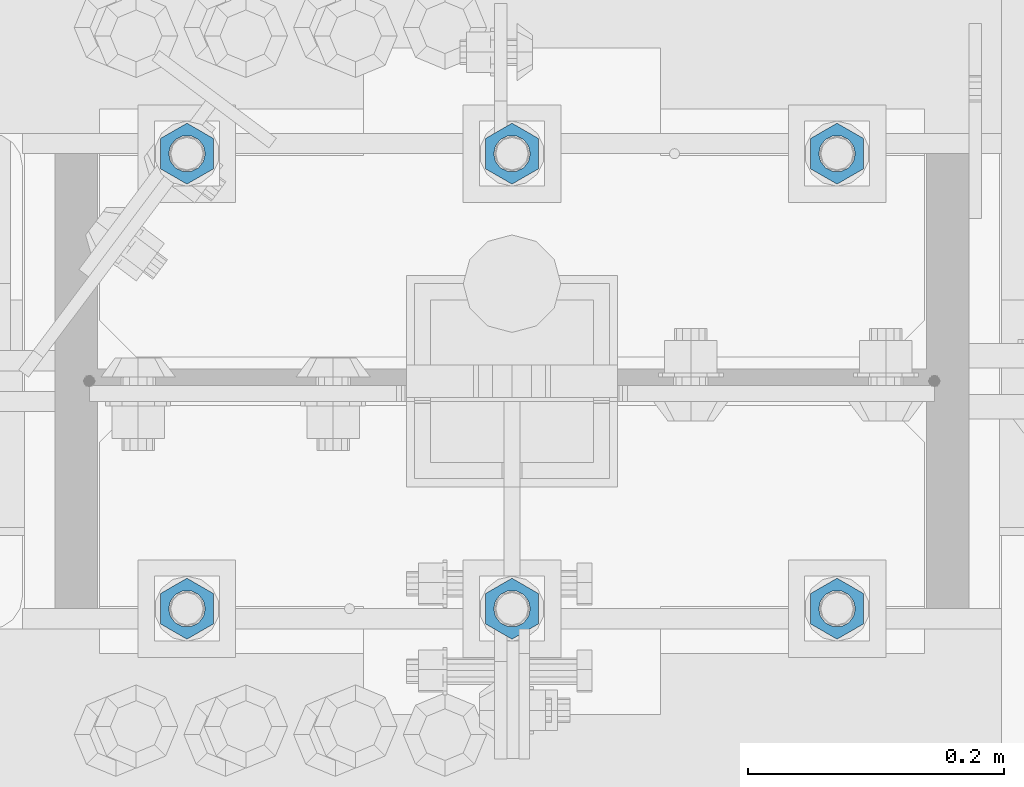
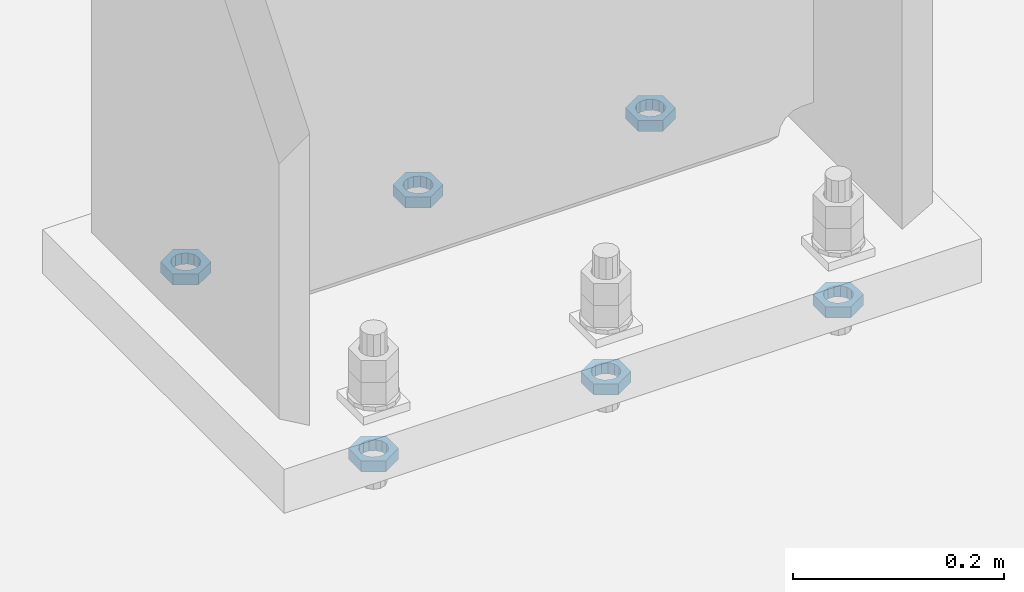
# One storey, part 1407 of 1763: 6 beams, 1 element without a shape of its own.
"""IFC2X3 building model written with IfcOpenShell, lengths in millimetres."""

from ifc_helpers import new_model, si_unit, frame, origin_with_axes, place, context, subcontext, project, spatial, faceted_brep, material, type_object, element, aggregate, save


model = new_model("IFC2X3")

# Units and contexts
model_context = context("Model", 3, precision=1e-05, world=origin_with_axes())
body_context = subcontext(model_context, "Body", "Model", "MODEL_VIEW")
ifc_project = project(units=[si_unit("LENGTHUNIT", "METRE", prefix="MILLI"), si_unit("AREAUNIT", "SQUARE_METRE"), si_unit("VOLUMEUNIT", "CUBIC_METRE"), si_unit("MASSUNIT", "GRAM", prefix="KILO"), si_unit("TIMEUNIT", "SECOND"), si_unit("PLANEANGLEUNIT", "RADIAN"), si_unit("SOLIDANGLEUNIT", "STERADIAN"), si_unit("THERMODYNAMICTEMPERATUREUNIT", "DEGREE_CELSIUS"), si_unit("LUMINOUSINTENSITYUNIT", "LUMEN")], contexts=[model_context])

# Site, building, storey
site_placement = place(None, origin_with_axes())
site = spatial("IfcSite", under=ifc_project, at=site_placement, CompositionType="ELEMENT")
building_placement = place(site_placement, origin_with_axes())
building = spatial("IfcBuilding", under=site, at=building_placement, Name="Undefined", CompositionType="ELEMENT")
storey_placement = place(building_placement, origin_with_axes())
storey = spatial("IfcBuildingStorey", under=building, at=storey_placement, Name="Undefined", CompositionType="ELEMENT", Elevation=0.0)

# Assembly, beams
assembly_placement = place(storey_placement, origin_with_axes())
assembly = element("IfcElementAssembly", 1, at=assembly_placement, inside=storey, Name="TEMPLATE", AssemblyPlace="NOTDEFINED", PredefinedType="RIGID_FRAME")
ifc_material = material(Name="STEEL/A563")
beam_type = type_object("IfcBeamType", Name="1_DIA. HALF_NUT", PredefinedType="NOTDEFINED")
beam_1_placement = place(assembly_placement, frame((-34695.8372736984, 52298.6, -266.699999999997), z_axis=(-1.0, 0.0, 0.0), x_axis=(0.0, 0.0, -1.0)))
beam_1 = element("IfcBeam", 2, at=beam_1_placement, type_object=beam_type, material=ifc_material, Name="NUT", ObjectType="1_DIA. HALF_NUT", context=body_context, shape_type="Brep", body=[
    faceted_brep([(0.0, -23.8099994659424, 0.0), (0.0, -11.9099998474121, -20.6200008392334), (12.7000000000001, -11.9099998474121, -20.6200008392334), (12.7000000000001, -23.8099994659424, 0.0), (0.0, 11.9099998474121, -20.6200008392334), (12.7000000000001, 11.9099998474121, -20.6200008392334), (0.0, 23.8099994659424, 0.0), (12.7000000000001, 23.8099994659424, 0.0), (0.0, 11.9099998474121, 20.6200008392334), (12.7000000000001, 11.9099998474121, 20.6200008392334), (0.0, -11.9099998474121, 20.6200008392334), (12.7000000000001, -11.9099998474121, 20.6200008392334), (0.0, 0.0, 14.289999961853), (0.0, 6.20019861543551, 12.8748450879575), (12.7000000000001, 6.20019861543551, 12.8748450879575), (12.7000000000001, 0.0, 14.289999961853), (0.0, 11.1723718546418, 8.90966924477834), (12.7000000000001, 11.1723718546418, 8.90966924477834), (0.0, 13.9317198278877, 3.17982413774735), (12.7000000000001, 13.9317198278877, 3.17982413774735), (0.0, 13.9317198278877, -3.17982413774735), (12.7000000000001, 13.9317198278877, -3.17982413774735), (0.0, 11.1723718546418, -8.90966924477834), (12.7000000000001, 11.1723718546418, -8.90966924477834), (0.0, 6.20019861543551, -12.8748450879575), (12.7000000000001, 6.20019861543551, -12.8748450879575), (0.0, 0.0, -14.289999961853), (12.7000000000001, 0.0, -14.289999961853), (0.0, -6.20019861543551, -12.8748450879575), (12.7000000000001, -6.20019861543551, -12.8748450879575), (0.0, -11.1723718546418, -8.90966924477834), (12.7000000000001, -11.1723718546418, -8.90966924477834), (0.0, -13.9317198278877, -3.17982413774735), (12.7000000000001, -13.9317198278877, -3.17982413774735), (0.0, -13.9317198278877, 3.17982413774735), (12.7000000000001, -13.9317198278877, 3.17982413774735), (0.0, -11.1723718546418, 8.90966924477834), (12.7000000000001, -11.1723718546418, 8.90966924477834), (0.0, -6.20019861543551, 12.8748450879575), (12.7000000000001, -6.20019861543551, 12.8748450879575)], [[[0, 1, 2, 3]], [[1, 4, 5, 2]], [[4, 6, 7, 5]], [[6, 8, 9, 7]], [[8, 10, 11, 9]], [[10, 0, 3, 11]], [[12, 13, 14, 15]], [[13, 16, 17, 14]], [[16, 18, 19, 17]], [[18, 20, 21, 19]], [[20, 22, 23, 21]], [[22, 24, 25, 23]], [[24, 26, 27, 25]], [[26, 28, 29, 27]], [[28, 30, 31, 29]], [[30, 32, 33, 31]], [[32, 34, 35, 33]], [[34, 36, 37, 35]], [[36, 38, 39, 37]], [[38, 12, 15, 39]], [[5, 7, 9, 11, 3, 2], [17, 19, 21, 23, 25, 27, 29, 31, 33, 35, 37, 39, 15, 14]], [[10, 8, 6, 4, 1, 0], [38, 36, 34, 32, 30, 28, 26, 24, 22, 20, 18, 16, 13, 12]]]),
])
beam_2_placement = place(assembly_placement, frame((-34949.8372736984, 52298.6, -266.699999999997), z_axis=(-1.0, 0.0, 0.0), x_axis=(0.0, 0.0, -1.0)))
beam_2 = element("IfcBeam", 3, at=beam_2_placement, type_object=beam_type, material=ifc_material, Name="NUT", ObjectType="1_DIA. HALF_NUT", context=body_context, shape_type="Brep", body=[
    faceted_brep([(0.0, -23.8099994659424, 0.0), (0.0, -11.9099998474121, -20.6200008392334), (12.7000000000001, -11.9099998474121, -20.6200008392334), (12.7000000000001, -23.8099994659424, 0.0), (0.0, 11.9099998474121, -20.6200008392334), (12.7000000000001, 11.9099998474121, -20.6200008392334), (0.0, 23.8099994659424, 0.0), (12.7000000000001, 23.8099994659424, 0.0), (0.0, 11.9099998474121, 20.6200008392334), (12.7000000000001, 11.9099998474121, 20.6200008392334), (0.0, -11.9099998474121, 20.6200008392334), (12.7000000000001, -11.9099998474121, 20.6200008392334), (0.0, 0.0, 14.289999961853), (0.0, 6.20019861543551, 12.8748450879575), (12.7000000000001, 6.20019861543551, 12.8748450879575), (12.7000000000001, 0.0, 14.289999961853), (0.0, 11.1723718546418, 8.90966924477834), (12.7000000000001, 11.1723718546418, 8.90966924477834), (0.0, 13.9317198278877, 3.17982413774735), (12.7000000000001, 13.9317198278877, 3.17982413774735), (0.0, 13.9317198278877, -3.17982413774735), (12.7000000000001, 13.9317198278877, -3.17982413774735), (0.0, 11.1723718546418, -8.90966924477834), (12.7000000000001, 11.1723718546418, -8.90966924477834), (0.0, 6.20019861543551, -12.8748450879575), (12.7000000000001, 6.20019861543551, -12.8748450879575), (0.0, 0.0, -14.289999961853), (12.7000000000001, 0.0, -14.289999961853), (0.0, -6.20019861543551, -12.8748450879575), (12.7000000000001, -6.20019861543551, -12.8748450879575), (0.0, -11.1723718546418, -8.90966924477834), (12.7000000000001, -11.1723718546418, -8.90966924477834), (0.0, -13.9317198278877, -3.17982413774735), (12.7000000000001, -13.9317198278877, -3.17982413774735), (0.0, -13.9317198278877, 3.17982413774735), (12.7000000000001, -13.9317198278877, 3.17982413774735), (0.0, -11.1723718546418, 8.90966924477834), (12.7000000000001, -11.1723718546418, 8.90966924477834), (0.0, -6.20019861543551, 12.8748450879575), (12.7000000000001, -6.20019861543551, 12.8748450879575)], [[[0, 1, 2, 3]], [[1, 4, 5, 2]], [[4, 6, 7, 5]], [[6, 8, 9, 7]], [[8, 10, 11, 9]], [[10, 0, 3, 11]], [[12, 13, 14, 15]], [[13, 16, 17, 14]], [[16, 18, 19, 17]], [[18, 20, 21, 19]], [[20, 22, 23, 21]], [[22, 24, 25, 23]], [[24, 26, 27, 25]], [[26, 28, 29, 27]], [[28, 30, 31, 29]], [[30, 32, 33, 31]], [[32, 34, 35, 33]], [[34, 36, 37, 35]], [[36, 38, 39, 37]], [[38, 12, 15, 39]], [[5, 7, 9, 11, 3, 2], [17, 19, 21, 23, 25, 27, 29, 31, 33, 35, 37, 39, 15, 14]], [[10, 8, 6, 4, 1, 0], [38, 36, 34, 32, 30, 28, 26, 24, 22, 20, 18, 16, 13, 12]]]),
])
beam_3_placement = place(assembly_placement, frame((-35203.8372736984, 52298.6, -266.699999999997), z_axis=(-1.0, 0.0, 0.0), x_axis=(0.0, 0.0, -1.0)))
beam_3 = element("IfcBeam", 4, at=beam_3_placement, type_object=beam_type, material=ifc_material, Name="NUT", ObjectType="1_DIA. HALF_NUT", context=body_context, shape_type="Brep", body=[
    faceted_brep([(0.0, -23.8099994659424, 0.0), (0.0, -11.9099998474121, -20.6200008392334), (12.7000000000001, -11.9099998474121, -20.6200008392334), (12.7000000000001, -23.8099994659424, 0.0), (0.0, 11.9099998474121, -20.6200008392334), (12.7000000000001, 11.9099998474121, -20.6200008392334), (0.0, 23.8099994659424, 0.0), (12.7000000000001, 23.8099994659424, 0.0), (0.0, 11.9099998474121, 20.6200008392334), (12.7000000000001, 11.9099998474121, 20.6200008392334), (0.0, -11.9099998474121, 20.6200008392334), (12.7000000000001, -11.9099998474121, 20.6200008392334), (0.0, 0.0, 14.289999961853), (0.0, 6.20019861543551, 12.8748450879575), (12.7000000000001, 6.20019861543551, 12.8748450879575), (12.7000000000001, 0.0, 14.289999961853), (0.0, 11.1723718546418, 8.90966924477834), (12.7000000000001, 11.1723718546418, 8.90966924477834), (0.0, 13.9317198278877, 3.17982413774735), (12.7000000000001, 13.9317198278877, 3.17982413774735), (0.0, 13.9317198278877, -3.17982413774735), (12.7000000000001, 13.9317198278877, -3.17982413774735), (0.0, 11.1723718546418, -8.90966924477834), (12.7000000000001, 11.1723718546418, -8.90966924477834), (0.0, 6.20019861543551, -12.8748450879575), (12.7000000000001, 6.20019861543551, -12.8748450879575), (0.0, 0.0, -14.289999961853), (12.7000000000001, 0.0, -14.289999961853), (0.0, -6.20019861543551, -12.8748450879575), (12.7000000000001, -6.20019861543551, -12.8748450879575), (0.0, -11.1723718546418, -8.90966924477834), (12.7000000000001, -11.1723718546418, -8.90966924477834), (0.0, -13.9317198278877, -3.17982413774735), (12.7000000000001, -13.9317198278877, -3.17982413774735), (0.0, -13.9317198278877, 3.17982413774735), (12.7000000000001, -13.9317198278877, 3.17982413774735), (0.0, -11.1723718546418, 8.90966924477834), (12.7000000000001, -11.1723718546418, 8.90966924477834), (0.0, -6.20019861543551, 12.8748450879575), (12.7000000000001, -6.20019861543551, 12.8748450879575)], [[[0, 1, 2, 3]], [[1, 4, 5, 2]], [[4, 6, 7, 5]], [[6, 8, 9, 7]], [[8, 10, 11, 9]], [[10, 0, 3, 11]], [[12, 13, 14, 15]], [[13, 16, 17, 14]], [[16, 18, 19, 17]], [[18, 20, 21, 19]], [[20, 22, 23, 21]], [[22, 24, 25, 23]], [[24, 26, 27, 25]], [[26, 28, 29, 27]], [[28, 30, 31, 29]], [[30, 32, 33, 31]], [[32, 34, 35, 33]], [[34, 36, 37, 35]], [[36, 38, 39, 37]], [[38, 12, 15, 39]], [[5, 7, 9, 11, 3, 2], [17, 19, 21, 23, 25, 27, 29, 31, 33, 35, 37, 39, 15, 14]], [[10, 8, 6, 4, 1, 0], [38, 36, 34, 32, 30, 28, 26, 24, 22, 20, 18, 16, 13, 12]]]),
])
beam_4_placement = place(assembly_placement, frame((-35203.8372736984, 51943.0, -266.699999999997), z_axis=(1.0, 0.0, 0.0), x_axis=(0.0, 0.0, -1.0)))
beam_4 = element("IfcBeam", 5, at=beam_4_placement, type_object=beam_type, material=ifc_material, Name="NUT", ObjectType="1_DIA. HALF_NUT", context=body_context, shape_type="Brep", body=[
    faceted_brep([(0.0, -23.8099994659424, 0.0), (0.0, -11.9099998474121, -20.6200008392334), (12.7000000000001, -11.9099998474121, -20.6200008392334), (12.7000000000001, -23.8099994659424, 0.0), (0.0, 11.9099998474121, -20.6200008392334), (12.7000000000001, 11.9099998474121, -20.6200008392334), (0.0, 23.8099994659424, 0.0), (12.7000000000001, 23.8099994659424, 0.0), (0.0, 11.9099998474121, 20.6200008392334), (12.7000000000001, 11.9099998474121, 20.6200008392334), (0.0, -11.9099998474121, 20.6200008392334), (12.7000000000001, -11.9099998474121, 20.6200008392334), (0.0, 0.0, 14.289999961853), (0.0, 6.20019861543551, 12.8748450879575), (12.7000000000001, 6.20019861543551, 12.8748450879575), (12.7000000000001, 0.0, 14.289999961853), (0.0, 11.1723718546418, 8.90966924477834), (12.7000000000001, 11.1723718546418, 8.90966924477834), (0.0, 13.9317198278877, 3.17982413774735), (12.7000000000001, 13.9317198278877, 3.17982413774735), (0.0, 13.9317198278877, -3.17982413774735), (12.7000000000001, 13.9317198278877, -3.17982413774735), (0.0, 11.1723718546418, -8.90966924477834), (12.7000000000001, 11.1723718546418, -8.90966924477834), (0.0, 6.20019861543551, -12.8748450879575), (12.7000000000001, 6.20019861543551, -12.8748450879575), (0.0, 0.0, -14.289999961853), (12.7000000000001, 0.0, -14.289999961853), (0.0, -6.20019861543551, -12.8748450879575), (12.7000000000001, -6.20019861543551, -12.8748450879575), (0.0, -11.1723718546418, -8.90966924477834), (12.7000000000001, -11.1723718546418, -8.90966924477834), (0.0, -13.9317198278877, -3.17982413774735), (12.7000000000001, -13.9317198278877, -3.17982413774735), (0.0, -13.9317198278877, 3.17982413774735), (12.7000000000001, -13.9317198278877, 3.17982413774735), (0.0, -11.1723718546418, 8.90966924477834), (12.7000000000001, -11.1723718546418, 8.90966924477834), (0.0, -6.20019861543551, 12.8748450879575), (12.7000000000001, -6.20019861543551, 12.8748450879575)], [[[0, 1, 2, 3]], [[1, 4, 5, 2]], [[4, 6, 7, 5]], [[6, 8, 9, 7]], [[8, 10, 11, 9]], [[10, 0, 3, 11]], [[12, 13, 14, 15]], [[13, 16, 17, 14]], [[16, 18, 19, 17]], [[18, 20, 21, 19]], [[20, 22, 23, 21]], [[22, 24, 25, 23]], [[24, 26, 27, 25]], [[26, 28, 29, 27]], [[28, 30, 31, 29]], [[30, 32, 33, 31]], [[32, 34, 35, 33]], [[34, 36, 37, 35]], [[36, 38, 39, 37]], [[38, 12, 15, 39]], [[5, 7, 9, 11, 3, 2], [17, 19, 21, 23, 25, 27, 29, 31, 33, 35, 37, 39, 15, 14]], [[10, 8, 6, 4, 1, 0], [38, 36, 34, 32, 30, 28, 26, 24, 22, 20, 18, 16, 13, 12]]]),
])
beam_5_placement = place(assembly_placement, frame((-34949.8372736984, 51943.0, -266.699999999997), z_axis=(1.0, 0.0, 0.0), x_axis=(0.0, 0.0, -1.0)))
beam_5 = element("IfcBeam", 6, at=beam_5_placement, type_object=beam_type, material=ifc_material, Name="NUT", ObjectType="1_DIA. HALF_NUT", context=body_context, shape_type="Brep", body=[
    faceted_brep([(0.0, -23.8099994659424, 0.0), (0.0, -11.9099998474121, -20.6200008392334), (12.7000000000001, -11.9099998474121, -20.6200008392334), (12.7000000000001, -23.8099994659424, 0.0), (0.0, 11.9099998474121, -20.6200008392334), (12.7000000000001, 11.9099998474121, -20.6200008392334), (0.0, 23.8099994659424, 0.0), (12.7000000000001, 23.8099994659424, 0.0), (0.0, 11.9099998474121, 20.6200008392334), (12.7000000000001, 11.9099998474121, 20.6200008392334), (0.0, -11.9099998474121, 20.6200008392334), (12.7000000000001, -11.9099998474121, 20.6200008392334), (0.0, 0.0, 14.289999961853), (0.0, 6.20019861543551, 12.8748450879575), (12.7000000000001, 6.20019861543551, 12.8748450879575), (12.7000000000001, 0.0, 14.289999961853), (0.0, 11.1723718546418, 8.90966924477834), (12.7000000000001, 11.1723718546418, 8.90966924477834), (0.0, 13.9317198278877, 3.17982413774735), (12.7000000000001, 13.9317198278877, 3.17982413774735), (0.0, 13.9317198278877, -3.17982413774735), (12.7000000000001, 13.9317198278877, -3.17982413774735), (0.0, 11.1723718546418, -8.90966924477834), (12.7000000000001, 11.1723718546418, -8.90966924477834), (0.0, 6.20019861543551, -12.8748450879575), (12.7000000000001, 6.20019861543551, -12.8748450879575), (0.0, 0.0, -14.289999961853), (12.7000000000001, 0.0, -14.289999961853), (0.0, -6.20019861543551, -12.8748450879575), (12.7000000000001, -6.20019861543551, -12.8748450879575), (0.0, -11.1723718546418, -8.90966924477834), (12.7000000000001, -11.1723718546418, -8.90966924477834), (0.0, -13.9317198278877, -3.17982413774735), (12.7000000000001, -13.9317198278877, -3.17982413774735), (0.0, -13.9317198278877, 3.17982413774735), (12.7000000000001, -13.9317198278877, 3.17982413774735), (0.0, -11.1723718546418, 8.90966924477834), (12.7000000000001, -11.1723718546418, 8.90966924477834), (0.0, -6.20019861543551, 12.8748450879575), (12.7000000000001, -6.20019861543551, 12.8748450879575)], [[[0, 1, 2, 3]], [[1, 4, 5, 2]], [[4, 6, 7, 5]], [[6, 8, 9, 7]], [[8, 10, 11, 9]], [[10, 0, 3, 11]], [[12, 13, 14, 15]], [[13, 16, 17, 14]], [[16, 18, 19, 17]], [[18, 20, 21, 19]], [[20, 22, 23, 21]], [[22, 24, 25, 23]], [[24, 26, 27, 25]], [[26, 28, 29, 27]], [[28, 30, 31, 29]], [[30, 32, 33, 31]], [[32, 34, 35, 33]], [[34, 36, 37, 35]], [[36, 38, 39, 37]], [[38, 12, 15, 39]], [[5, 7, 9, 11, 3, 2], [17, 19, 21, 23, 25, 27, 29, 31, 33, 35, 37, 39, 15, 14]], [[10, 8, 6, 4, 1, 0], [38, 36, 34, 32, 30, 28, 26, 24, 22, 20, 18, 16, 13, 12]]]),
])
beam_6_placement = place(assembly_placement, frame((-34695.8372736984, 51943.0, -266.699999999997), z_axis=(1.0, 0.0, 0.0), x_axis=(0.0, 0.0, -1.0)))
beam_6 = element("IfcBeam", 7, at=beam_6_placement, type_object=beam_type, material=ifc_material, Name="NUT", ObjectType="1_DIA. HALF_NUT", context=body_context, shape_type="Brep", body=[
    faceted_brep([(0.0, -23.8099994659424, 0.0), (0.0, -11.9099998474121, -20.6200008392334), (12.7000000000001, -11.9099998474121, -20.6200008392334), (12.7000000000001, -23.8099994659424, 0.0), (0.0, 11.9099998474121, -20.6200008392334), (12.7000000000001, 11.9099998474121, -20.6200008392334), (0.0, 23.8099994659424, 0.0), (12.7000000000001, 23.8099994659424, 0.0), (0.0, 11.9099998474121, 20.6200008392334), (12.7000000000001, 11.9099998474121, 20.6200008392334), (0.0, -11.9099998474121, 20.6200008392334), (12.7000000000001, -11.9099998474121, 20.6200008392334), (0.0, 0.0, 14.289999961853), (0.0, 6.20019861543551, 12.8748450879575), (12.7000000000001, 6.20019861543551, 12.8748450879575), (12.7000000000001, 0.0, 14.289999961853), (0.0, 11.1723718546418, 8.90966924477834), (12.7000000000001, 11.1723718546418, 8.90966924477834), (0.0, 13.9317198278877, 3.17982413774735), (12.7000000000001, 13.9317198278877, 3.17982413774735), (0.0, 13.9317198278877, -3.17982413774735), (12.7000000000001, 13.9317198278877, -3.17982413774735), (0.0, 11.1723718546418, -8.90966924477834), (12.7000000000001, 11.1723718546418, -8.90966924477834), (0.0, 6.20019861543551, -12.8748450879575), (12.7000000000001, 6.20019861543551, -12.8748450879575), (0.0, 0.0, -14.289999961853), (12.7000000000001, 0.0, -14.289999961853), (0.0, -6.20019861543551, -12.8748450879575), (12.7000000000001, -6.20019861543551, -12.8748450879575), (0.0, -11.1723718546418, -8.90966924477834), (12.7000000000001, -11.1723718546418, -8.90966924477834), (0.0, -13.9317198278877, -3.17982413774735), (12.7000000000001, -13.9317198278877, -3.17982413774735), (0.0, -13.9317198278877, 3.17982413774735), (12.7000000000001, -13.9317198278877, 3.17982413774735), (0.0, -11.1723718546418, 8.90966924477834), (12.7000000000001, -11.1723718546418, 8.90966924477834), (0.0, -6.20019861543551, 12.8748450879575), (12.7000000000001, -6.20019861543551, 12.8748450879575)], [[[0, 1, 2, 3]], [[1, 4, 5, 2]], [[4, 6, 7, 5]], [[6, 8, 9, 7]], [[8, 10, 11, 9]], [[10, 0, 3, 11]], [[12, 13, 14, 15]], [[13, 16, 17, 14]], [[16, 18, 19, 17]], [[18, 20, 21, 19]], [[20, 22, 23, 21]], [[22, 24, 25, 23]], [[24, 26, 27, 25]], [[26, 28, 29, 27]], [[28, 30, 31, 29]], [[30, 32, 33, 31]], [[32, 34, 35, 33]], [[34, 36, 37, 35]], [[36, 38, 39, 37]], [[38, 12, 15, 39]], [[5, 7, 9, 11, 3, 2], [17, 19, 21, 23, 25, 27, 29, 31, 33, 35, 37, 39, 15, 14]], [[10, 8, 6, 4, 1, 0], [38, 36, 34, 32, 30, 28, 26, 24, 22, 20, 18, 16, 13, 12]]]),
])
aggregate(assembly, [beam_1, beam_2, beam_3, beam_4, beam_5, beam_6])

save(model, "model.ifc")
